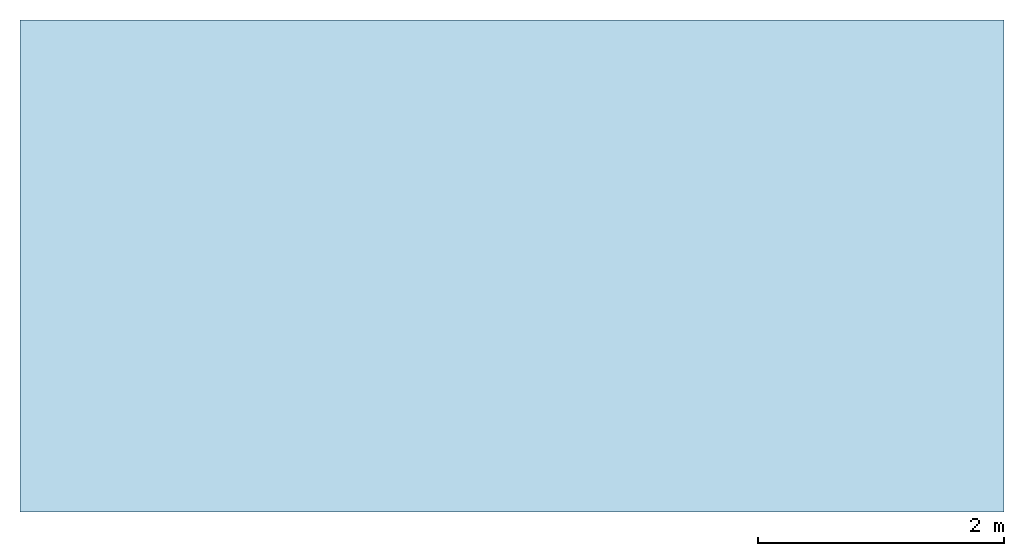
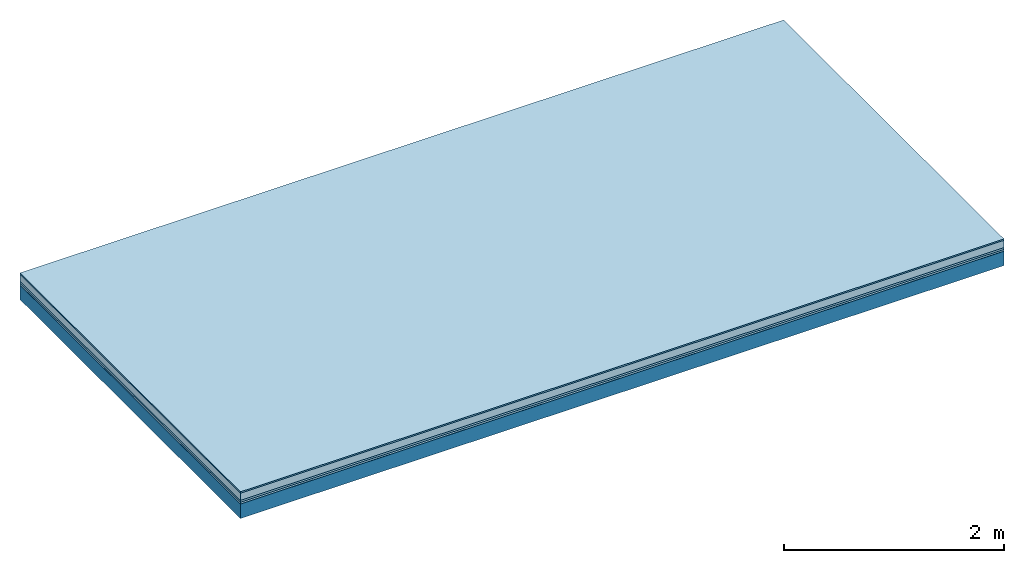
# One storey: 5 plates, 1 member, 1 element without a shape of its own.
"""IFC4 building model written with IfcOpenShell, lengths in metres."""

from ifc_helpers import new_model, si_unit, derived_unit, direction, frame, frame_2d, origin, origin_with_axes, place, context, project, spatial, rectangle, extrude, material, layer, layer_set, type_object, element, aggregate, save


model = new_model("IFC4")

# Units and contexts
plan_context = context("Plan", 3, precision=1e-05, world=origin(), true_north=direction((0.0, 1.0)))
model_context = context("Model", 3, precision=1e-05, world=origin(), true_north=direction((0.0, 1.0)))
ifc_project = project(units=[si_unit("LENGTHUNIT", "METRE"), derived_unit("SOUNDPRESSUREUNIT", [(si_unit("PRESSUREUNIT", "PASCAL", prefix="MICRO"), 0)]), si_unit("ENERGYUNIT", "JOULE", prefix="MEGA"), si_unit("MASSUNIT", "GRAM", prefix="KILO"), derived_unit("THERMALTRANSMITTANCEUNIT", [(si_unit("POWERUNIT", "WATT"), 1), (si_unit("AREAUNIT", "SQUARE_METRE"), -1), (si_unit("THERMODYNAMICTEMPERATUREUNIT", "KELVIN"), -1)]), derived_unit("AREADENSITYUNIT", [(si_unit("MASSUNIT", "GRAM", prefix="KILO"), 1), (si_unit("AREAUNIT", "SQUARE_METRE"), -1)]), derived_unit("USERDEFINED", [(si_unit("ENERGYUNIT", "JOULE", prefix="MEGA"), 1), (si_unit("AREAUNIT", "SQUARE_METRE"), -1)])], contexts=[plan_context, model_context])

# Site, building, storey
site = spatial("IfcSite", under=ifc_project)
building_placement = place(None, origin())
building = spatial("IfcBuilding", under=site, at=building_placement)
storey_placement = place(building_placement, origin())
storey = spatial("IfcBuildingStorey", under=building, at=storey_placement)

# Slab, member, plates
ifc_material_1 = material(Category="11.013")
ifc_layer_1 = layer(ifc_material_1, 0.015, Name="Flooring")
ifc_material_2 = material(Name="Cement screed", Category="04.006")
ifc_layer_2 = layer(ifc_material_2, 0.08, Name="On-material")
ifc_material_3 = material(Name="Wood fiber generic product", Category="10.009")
ifc_layer_3 = layer(ifc_material_3, 0.02, Name="Impact sound insulation")
ifc_material_4 = material()
ifc_layer_4 = layer(ifc_material_4, 0.02, Name="Additional insulation")
ifc_material_5 = material(Name="protection", Category="09.007")
ifc_layer_5 = layer(ifc_material_5, 0.0005, Name="Sub-floor")
ifc_material_6 = material(Name="no composite action")
ifc_layer_6 = layer(ifc_material_6, 0.0, Name="Bond")
ifc_layer_7 = layer(None, 0.16, Name="Supporting structure")
ifc_layer_set = layer_set([ifc_layer_1, ifc_layer_2, ifc_layer_3, ifc_layer_4, ifc_layer_5, ifc_layer_6, ifc_layer_7])
slab_type = type_object("IfcSlabType", Name="A2071", PredefinedType="NOTDEFINED", material=ifc_layer_set)
slab_placement = place(None, frame((0.0, 0.0, 0.0), z_axis=(0.0, 0.0, -1.0), x_axis=(1.0, 0.0, 0.0)))
slab = element("IfcSlab", 1, at=slab_placement, inside=storey, type_object=slab_type, material=ifc_layer_set, Name="Slab #1")
ifc_material_7 = material(Name="Solid timber panel")
member_placement = place(slab_placement, origin())
member = element("IfcMember", 2, at=member_placement, material=ifc_material_7, Name="Supporting structure", context=plan_context, shape_type="SweptSolid", body=[
    extrude(rectangle(XDim=1.0, YDim=0.16, at=frame_2d((0.5, 0.08), x_axis=(1.0, 0.0))), frame((0.0, 4.0, 0.1355), z_axis=(0.0, -1.0, 0.0), x_axis=(1.0, 0.0, 0.0)), (0.0, 0.0, 1.0), 4.0),
    extrude(rectangle(XDim=1.0, YDim=0.16, at=frame_2d((0.5, 0.08), x_axis=(1.0, 0.0))), frame((1.0, 4.0, 0.1355), z_axis=(0.0, -1.0, 0.0), x_axis=(1.0, 0.0, 0.0)), (0.0, 0.0, 1.0), 4.0),
    extrude(rectangle(XDim=1.0, YDim=0.16, at=frame_2d((0.5, 0.08), x_axis=(1.0, 0.0))), frame((2.0, 4.0, 0.1355), z_axis=(0.0, -1.0, 0.0), x_axis=(1.0, 0.0, 0.0)), (0.0, 0.0, 1.0), 4.0),
    extrude(rectangle(XDim=1.0, YDim=0.16, at=frame_2d((0.5, 0.08), x_axis=(1.0, 0.0))), frame((3.0, 4.0, 0.1355), z_axis=(0.0, -1.0, 0.0), x_axis=(1.0, 0.0, 0.0)), (0.0, 0.0, 1.0), 4.0),
    extrude(rectangle(XDim=1.0, YDim=0.16, at=frame_2d((0.5, 0.08), x_axis=(1.0, 0.0))), frame((4.0, 4.0, 0.1355), z_axis=(0.0, -1.0, 0.0), x_axis=(1.0, 0.0, 0.0)), (0.0, 0.0, 1.0), 4.0),
    extrude(rectangle(XDim=1.0, YDim=0.16, at=frame_2d((0.5, 0.08), x_axis=(1.0, 0.0))), frame((5.0, 4.0, 0.1355), z_axis=(0.0, -1.0, 0.0), x_axis=(1.0, 0.0, 0.0)), (0.0, 0.0, 1.0), 4.0),
    extrude(rectangle(XDim=1.0, YDim=0.16, at=frame_2d((0.5, 0.08), x_axis=(1.0, 0.0))), frame((6.0, 4.0, 0.1355), z_axis=(0.0, -1.0, 0.0), x_axis=(1.0, 0.0, 0.0)), (0.0, 0.0, 1.0), 4.0),
    extrude(rectangle(XDim=1.0, YDim=0.16, at=frame_2d((0.5, 0.08), x_axis=(1.0, 0.0))), frame((7.0, 4.0, 0.1355), z_axis=(0.0, -1.0, 0.0), x_axis=(1.0, 0.0, 0.0)), (0.0, 0.0, 1.0), 4.0),
])
plate_1_placement = place(slab_placement, origin())
plate_1 = element("IfcPlate", 3, at=plate_1_placement, material=ifc_material_1, Name="Flooring", context=plan_context, shape_type="SweptSolid", body=[
    extrude(rectangle(XDim=8.0, YDim=4.0, at=frame_2d((4.0, 2.0), x_axis=(1.0, 0.0))), origin_with_axes(), (0.0, 0.0, 1.0), 0.015),
])
plate_2_placement = place(slab_placement, origin())
plate_2 = element("IfcPlate", 4, at=plate_2_placement, material=ifc_material_2, Name="On-material", context=plan_context, shape_type="SweptSolid", body=[
    extrude(rectangle(XDim=8.0, YDim=4.0, at=frame_2d((4.0, 2.0), x_axis=(1.0, 0.0))), frame((0.0, 0.0, 0.015), z_axis=(0.0, 0.0, 1.0), x_axis=(1.0, 0.0, 0.0)), (0.0, 0.0, 1.0), 0.08),
])
plate_3_placement = place(slab_placement, origin())
plate_3 = element("IfcPlate", 5, at=plate_3_placement, material=ifc_material_3, Name="Impact sound insulation", context=plan_context, shape_type="SweptSolid", body=[
    extrude(rectangle(XDim=8.0, YDim=4.0, at=frame_2d((4.0, 2.0), x_axis=(1.0, 0.0))), frame((0.0, 0.0, 0.095), z_axis=(0.0, 0.0, 1.0), x_axis=(1.0, 0.0, 0.0)), (0.0, 0.0, 1.0), 0.02),
])
plate_4_placement = place(slab_placement, origin())
plate_4 = element("IfcPlate", 6, at=plate_4_placement, material=ifc_material_4, Name="Additional insulation", context=plan_context, shape_type="SweptSolid", body=[
    extrude(rectangle(XDim=8.0, YDim=4.0, at=frame_2d((4.0, 2.0), x_axis=(1.0, 0.0))), frame((0.0, 0.0, 0.115), z_axis=(0.0, 0.0, 1.0), x_axis=(1.0, 0.0, 0.0)), (0.0, 0.0, 1.0), 0.02),
])
plate_5_placement = place(slab_placement, origin())
plate_5 = element("IfcPlate", 7, at=plate_5_placement, material=ifc_material_5, Name="Sub-floor", context=plan_context, shape_type="SweptSolid", body=[
    extrude(rectangle(XDim=8.0, YDim=4.0, at=frame_2d((4.0, 2.0), x_axis=(1.0, 0.0))), frame((0.0, 0.0, 0.135), z_axis=(0.0, 0.0, 1.0), x_axis=(1.0, 0.0, 0.0)), (0.0, 0.0, 1.0), 0.0005),
])
aggregate(slab, [plate_1, plate_2, plate_3, plate_4, plate_5, member])

save(model, "model.ifc")
